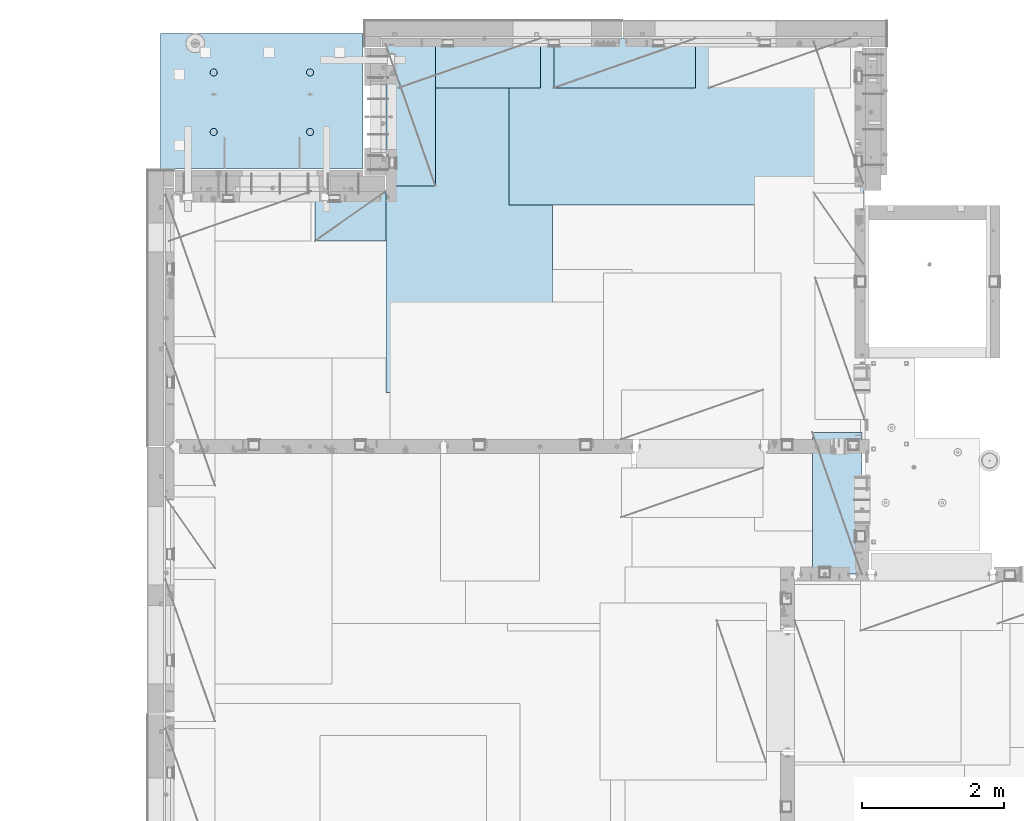
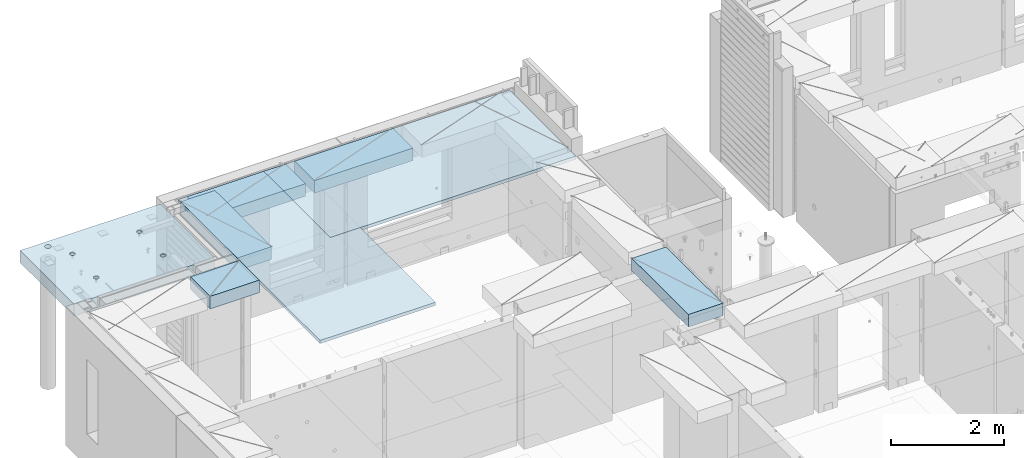
# One storey, part 176 of 309: 7 plates, 1 slab, 8 elements without a shape of their own.
"""IFC2X3 building model written with IfcOpenShell, lengths in millimetres."""

from ifc_helpers import new_model, si_unit, frame, origin_with_axes, place, context, subcontext, project, spatial, faceted_brep, material, type_object, element, aggregate, save


model = new_model("IFC2X3")

# Units and contexts
model_context = context("Model", 3, precision=1e-05, world=origin_with_axes())
body_context = subcontext(model_context, "Body", "Model", "MODEL_VIEW")
ifc_project = project(units=[si_unit("LENGTHUNIT", "METRE", prefix="MILLI"), si_unit("AREAUNIT", "SQUARE_METRE"), si_unit("VOLUMEUNIT", "CUBIC_METRE"), si_unit("MASSUNIT", "GRAM", prefix="KILO"), si_unit("TIMEUNIT", "SECOND"), si_unit("PLANEANGLEUNIT", "RADIAN"), si_unit("SOLIDANGLEUNIT", "STERADIAN"), si_unit("THERMODYNAMICTEMPERATUREUNIT", "DEGREE_CELSIUS"), si_unit("LUMINOUSINTENSITYUNIT", "LUMEN")], contexts=[model_context])

# Site, building, storey
site_placement = place(None, origin_with_axes())
site = spatial("IfcSite", under=ifc_project, at=site_placement, CompositionType="ELEMENT")
building_placement = place(site_placement, origin_with_axes())
building = spatial("IfcBuilding", under=site, at=building_placement, CompositionType="ELEMENT")
storey_placement = place(building_placement, origin_with_axes())
storey = spatial("IfcBuildingStorey", under=building, at=storey_placement, Name="7", CompositionType="ELEMENT", Elevation=0.0)

# Assembly, plate
assembly_1_placement = place(storey_placement, origin_with_axes())
assembly_1 = element("IfcElementAssembly", 1, at=assembly_1_placement, inside=storey, Name="Steel Assembly", AssemblyPlace="NOTDEFINED", PredefinedType="NOTDEFINED")
ifc_material_1 = material()
plate_type_1 = type_object("IfcPlateType", PredefinedType="NOTDEFINED")
plate_1_placement = place(assembly_1_placement, frame((12729.9998779297, 22740.0009765625, 102695.1), z_axis=(1.0, 0.0, 0.0), x_axis=(0.0, -1.0, 0.0)))
plate_1 = element("IfcPlate", 2, at=plate_1_placement, type_object=plate_type_1, material=ifc_material_1, context=body_context, shape_type="Brep", body=[
    faceted_brep([(0.0, -35.0, 0.0), (0.0, -35.0, 5000.0), (0.0, 35.0, 5000.0), (0.0, 35.0, 0.0), (2349.99951171875, -35.0, 5000.0), (2349.99951171875, 35.0, 5000.0), (2350.0, -35.0, 0.0), (2350.0, 35.0, 0.0)], [[[0, 1, 2, 3]], [[1, 4, 5, 2]], [[4, 6, 7, 5]], [[6, 0, 3, 7]], [[5, 7, 3, 2]], [[6, 4, 1, 0]]]),
])
aggregate(assembly_1, [plate_1])

assembly_2_placement = place(storey_placement, origin_with_axes())
assembly_2 = element("IfcElementAssembly", 3, at=assembly_2_placement, inside=storey, Name="Steel Assembly", AssemblyPlace="NOTDEFINED", PredefinedType="NOTDEFINED")
plate_2_placement = place(assembly_2_placement, frame((13340.0, 22740.0, 102695.1), z_axis=(0.0, -1.0, 0.0), x_axis=(-1.0, 3.00000001838171e-08, 0.0)))
plate_2 = element("IfcPlate", 4, at=plate_2_placement, type_object=plate_type_1, material=ifc_material_1, context=body_context, shape_type="Brep", body=[
    faceted_brep([(0.0, -35.0, 0.0), (0.0, -35.0, 5000.0), (0.0, 35.0, 5000.0), (0.0, 35.0, 0.0), (2349.99951171875, -35.0, 5000.0), (2349.99951171875, 35.0, 5000.0), (2350.0, -35.0, 0.0), (2350.0, 35.0, 0.0)], [[[0, 1, 2, 3]], [[1, 4, 5, 2]], [[4, 6, 7, 5]], [[6, 0, 3, 7]], [[5, 7, 3, 2]], [[6, 4, 1, 0]]]),
])
aggregate(assembly_2, [plate_2])

assembly_3_placement = place(storey_placement, origin_with_axes())
assembly_3 = element("IfcElementAssembly", 5, at=assembly_3_placement, inside=storey, Name="Steel Assembly", AssemblyPlace="NOTDEFINED", PredefinedType="NOTDEFINED")
plate_type_2 = type_object("IfcPlateType", PredefinedType="NOTDEFINED")
plate_3_placement = place(assembly_3_placement, frame((17710.0001220703, 15180.0, 102595.3), z_axis=(-1.0, 3.00000001838171e-08, 0.0), x_axis=(0.0, 1.0, 0.0)))
plate_3 = element("IfcPlate", 6, at=plate_3_placement, type_object=plate_type_2, material=ifc_material_1, Name="RE1", context=body_context, shape_type="Brep", body=[
    faceted_brep([(1.81898940354586e-12, -135.0, 1.81898940354586e-12), (0.0, -135.0, 699.999999999996), (0.0, 135.0, 699.999999999996), (1.81898940354586e-12, 135.0, 1.81898940354586e-12), (1999.99951171875, -135.0, 699.999999999993), (1999.99951171875, 135.0, 699.999999999993), (2000.0, -135.0, -3.63797880709171e-12), (2000.0, 135.0, -3.63797880709171e-12)], [[[0, 1, 2, 3]], [[1, 4, 5, 2]], [[4, 6, 7, 5]], [[6, 0, 3, 7]], [[5, 7, 3, 2]], [[6, 4, 1, 0]]]),
])
aggregate(assembly_3, [plate_3])

assembly_4_placement = place(storey_placement, origin_with_axes())
assembly_4 = element("IfcElementAssembly", 7, at=assembly_4_placement, inside=storey, Name="Steel Assembly", AssemblyPlace="NOTDEFINED", PredefinedType="NOTDEFINED")
plate_4_placement = place(assembly_4_placement, frame((13175.0, 22740.0001220703, 102595.3), z_axis=(0.0, -1.0, 0.0), x_axis=(-1.0, 3.00000001838171e-08, 0.0)))
plate_4 = element("IfcPlate", 8, at=plate_4_placement, type_object=plate_type_2, material=ifc_material_1, Name="RE1", context=body_context, shape_type="Brep", body=[
    faceted_brep([(1.81898940354586e-12, -135.0, 1.81898940354586e-12), (0.0, -135.0, 699.999999999996), (0.0, 135.0, 699.999999999996), (1.81898940354586e-12, 135.0, 1.81898940354586e-12), (1999.99951171875, -135.0, 699.999999999993), (1999.99951171875, 135.0, 699.999999999993), (2000.0, -135.0, -3.63797880709171e-12), (2000.0, 135.0, -3.63797880709171e-12)], [[[0, 1, 2, 3]], [[1, 4, 5, 2]], [[4, 6, 7, 5]], [[6, 0, 3, 7]], [[5, 7, 3, 2]], [[6, 4, 1, 0]]]),
])
aggregate(assembly_4, [plate_4])

assembly_5_placement = place(storey_placement, origin_with_axes())
assembly_5 = element("IfcElementAssembly", 9, at=assembly_5_placement, inside=storey, Name="Steel Assembly", AssemblyPlace="NOTDEFINED", PredefinedType="NOTDEFINED")
plate_5_placement = place(assembly_5_placement, frame((15360.0, 22740.0001220703, 102595.3), z_axis=(0.0, -1.0, 0.0), x_axis=(-1.0, 3.00000001838171e-08, 0.0)))
plate_5 = element("IfcPlate", 10, at=plate_5_placement, type_object=plate_type_2, material=ifc_material_1, Name="RE1", context=body_context, shape_type="Brep", body=[
    faceted_brep([(1.81898940354586e-12, -135.0, 1.81898940354586e-12), (0.0, -135.0, 699.999999999996), (0.0, 135.0, 699.999999999996), (1.81898940354586e-12, 135.0, 1.81898940354586e-12), (1999.99951171875, -135.0, 699.999999999993), (1999.99951171875, 135.0, 699.999999999993), (2000.0, -135.0, -3.63797880709171e-12), (2000.0, 135.0, -3.63797880709171e-12)], [[[0, 1, 2, 3]], [[1, 4, 5, 2]], [[4, 6, 7, 5]], [[6, 0, 3, 7]], [[5, 7, 3, 2]], [[6, 4, 1, 0]]]),
])
aggregate(assembly_5, [plate_5])

assembly_6_placement = place(storey_placement, origin_with_axes())
assembly_6 = element("IfcElementAssembly", 11, at=assembly_6_placement, inside=storey, Name="Steel Assembly", AssemblyPlace="NOTDEFINED", PredefinedType="NOTDEFINED")
plate_6_placement = place(assembly_6_placement, frame((10989.9998779297, 22660.0, 102595.3), z_axis=(1.0, 0.0, 0.0), x_axis=(0.0, -1.0, 0.0)))
plate_6 = element("IfcPlate", 12, at=plate_6_placement, type_object=plate_type_2, material=ifc_material_1, Name="RE1", context=body_context, shape_type="Brep", body=[
    faceted_brep([(1.81898940354586e-12, -135.0, 1.81898940354586e-12), (0.0, -135.0, 699.999999999996), (0.0, 135.0, 699.999999999996), (1.81898940354586e-12, 135.0, 1.81898940354586e-12), (1999.99951171875, -135.0, 699.999999999993), (1999.99951171875, 135.0, 699.999999999993), (2000.0, -135.0, -3.63797880709171e-12), (2000.0, 135.0, -3.63797880709171e-12)], [[[0, 1, 2, 3]], [[1, 4, 5, 2]], [[4, 6, 7, 5]], [[6, 0, 3, 7]], [[5, 7, 3, 2]], [[6, 4, 1, 0]]]),
])
aggregate(assembly_6, [plate_6])

assembly_7_placement = place(storey_placement, origin_with_axes())
assembly_7 = element("IfcElementAssembly", 13, at=assembly_7_placement, inside=storey, Name="Steel Assembly", AssemblyPlace="NOTDEFINED", PredefinedType="NOTDEFINED")
plate_7_placement = place(assembly_7_placement, frame((10990.0, 20580.0000000707, 102595.3), z_axis=(0.0, -1.0, 0.0), x_axis=(-1.0, 3.00000001838171e-08, 0.0)))
plate_7 = element("IfcPlate", 14, at=plate_7_placement, type_object=plate_type_2, material=ifc_material_1, Name="RE1_1/2", context=body_context, shape_type="Brep", body=[
    faceted_brep([(1.81898940354586e-12, -135.0, 1.81898940354586e-12), (0.0, -135.0, 699.999999999996), (0.0, 135.0, 699.999999999996), (1.81898940354586e-12, 135.0, 1.81898940354586e-12), (999.99951171875, -135.0, 700.0), (999.99951171875, 135.0, 700.0), (1000.0, -135.0, 0.0), (1000.0, 135.0, 0.0)], [[[0, 1, 2, 3]], [[1, 4, 5, 2]], [[4, 6, 7, 5]], [[6, 0, 3, 7]], [[5, 7, 3, 2]], [[6, 4, 1, 0]]]),
])
aggregate(assembly_7, [plate_7])

# Assembly, slab
assembly_8_placement = place(storey_placement, origin_with_axes())
assembly_8 = element("IfcElementAssembly", 15, at=assembly_8_placement, inside=storey, AssemblyPlace="NOTDEFINED", PredefinedType="REINFORCEMENT_UNIT")
ifc_material_2 = material(Name="CONCRETE/C35/45")
slab_type = type_object("IfcSlabType", PredefinedType="NOTDEFINED")
slab_placement = place(assembly_8_placement, frame((7810.00985681325, 20899.9965573523, 102575.0), z_axis=(-2.2639999995273e-06, 0.999999999997437, 0.0), x_axis=(0.999999999997251, 2.34499999952812e-06, 0.0)))
slab = element("IfcSlab", 16, at=slab_placement, type_object=slab_type, material=ifc_material_2, PredefinedType="FLOOR", context=body_context, shape_type="Brep", body=[
    faceted_brep([(2125.44400874935, -110.0, 1312.44480491596), (2139.38243873964, -110.0, 1319.54674746219), (2150.44405246897, -110.0, 1330.60830794105), (2157.54606211472, -110.0, 1344.54670374242), (2159.99327349015, -110.0, 1359.99754757078), (2157.54613649511, -110.0, 1375.44840317983), (2150.44419394888, -110.0, 1389.38683317012), (2139.38263347003, -110.0, 1400.44844689945), (2125.44423766865, -110.0, 1407.5504565452), (2109.9933938403, -110.0, 1409.99766792063), (2094.54253823125, -110.0, 1407.55053092559), (2080.60410824096, -110.0, 1400.44858837936), (2069.54249451162, -110.0, 1389.38702790051), (2062.44048486587, -110.0, 1375.44863209913), (2059.99327349044, -110.0, 1359.99778827078), (2062.44041048548, -110.0, 1344.54693266172), (2069.54235303171, -110.0, 1330.60850267144), (2080.60391351056, -110.0, 1319.5468889421), (2094.54230931194, -110.0, 1312.44487929635), (2109.9931531403, -110.0, 1309.99766792092), (2151.40731110266, -130.000000000015, 1390.08657519986), (2158.67834751904, -130.000000000015, 1375.81627782885), (2140.08238013622, -130.000000000015, 1401.41156068466), (2125.81211776814, -130.000000000015, 1408.68266579816), (2109.99339670578, -130.000000000015, 1411.1881441111), (2094.17466358222, -130.000000000015, 1408.68274194951), (2079.90436621121, -130.000000000015, 1401.41170553314), (2068.57938072642, -130.000000000015, 1390.08677456669), (2061.30827561291, -130.000000000015, 1375.81651219862), (2058.80279729997, -130.000000000015, 1359.99779113625), (2061.30819946156, -130.000000000015, 1344.1790580127), (2068.57923587794, -130.000000000015, 1329.90876064169), (2079.90416684438, -130.000000000015, 1318.58377515689), (2094.17442921246, -130.000000000015, 1311.31267004339), (2109.99315027482, -130.000000000015, 1308.80719173045), (2125.81188339837, -130.000000000015, 1311.31259389204), (2140.08218076939, -130.000000000015, 1318.58363030841), (2151.40716625418, -130.000000000015, 1329.90856127486), (2158.67827136769, -130.000000000015, 1344.17882364294), (2161.18374968063, -130.000000000015, 1359.9975447053), (765.444008782275, -110.0, 1312.44807834489), (779.382438772569, -110.0, 1319.55002089111), (790.444052501902, -110.0, 1330.61158136997), (797.546062147649, -110.0, 1344.54997717134), (799.99327352308, -110.0, 1360.0008209997), (797.546136528039, -110.0, 1375.45167660875), (790.444193981812, -110.0, 1389.39010659904), (779.382633502959, -110.0, 1400.45172032838), (765.444237701578, -110.0, 1407.55372997412), (749.993393873225, -110.0, 1410.00094134955), (734.542538264175, -110.0, 1407.55380435451), (720.604108273881, -110.0, 1400.45186180829), (709.54249454455, -110.0, 1389.39030132943), (702.440484898802, -110.0, 1375.45190552806), (699.993273523371, -110.0, 1360.0010616997), (702.440410518411, -110.0, 1344.55020609065), (709.54235306464, -110.0, 1330.61177610036), (720.603913543491, -110.0, 1319.55016237102), (734.542309344872, -110.0, 1312.44815272528), (749.993153173225, -110.0, 1310.00094134984), (798.678347551964, -130.0, 1375.81955125778), (801.183749713553, -130.0, 1360.00081813422), (791.407311135587, -130.0, 1390.08984862879), (780.082380169144, -130.0, 1401.41483411358), (765.812117801064, -130.0, 1408.68593922709), (749.993396738702, -130.0, 1411.19141754003), (734.174663615149, -130.0, 1408.68601537844), (719.904366244136, -130.0, 1401.41497896206), (708.579380759344, -130.0, 1390.09004799561), (701.308275645839, -130.0, 1375.81978562754), (698.802797332895, -130.0, 1360.00106456517), (701.308199494486, -130.0, 1344.18233144163), (708.579235910864, -130.0, 1329.91203407061), (719.904166877308, -130.0, 1318.58704858582), (734.174429245386, -130.0, 1311.31594347231), (749.99315030775, -130.0, 1308.81046515937), (765.811883431301, -130.0, 1311.31586732096), (780.082180802316, -130.0, 1318.58690373734), (791.407166287107, -130.0, 1329.91183470378), (798.678271400611, -130.0, 1344.18209707186), (2859.98999023438, -130.0, -1.11685949377716e-09), (0.0, -130.0, -3.63797880709171e-12), (0.0, 130.0, -1.81898940354586e-12), (2859.98999023438, 130.0, -1.11685949377716e-09), (2859.99145507813, -130.0, 1910.00366210938), (2859.99145507813, 130.0, 1910.00366210938), (0.00121913256589323, -130.0, 1910.00366210938), (0.00121913256589323, 130.0, 1910.00366210938), (538.534303374119, 130.0, 1805.28415037586), (525.260430799499, 130.0, 1818.55808685106), (508.534355837841, 130.0, 1827.08049842596), (489.993343243817, 130.0, 1830.01715207647), (471.452316512958, 130.0, 1827.08058768242), (454.726200524605, 130.0, 1818.55825662695), (441.452264049407, 130.0, 1805.28438405233), (432.929852474508, 130.0, 1788.55830909067), (429.993198823991, 130.0, 1770.01729649665), (432.929763218039, 130.0, 1751.47626976578), (441.452094273514, 130.0, 1734.75015377744), (454.725966848137, 130.0, 1721.47621730223), (471.452041809793, 130.0, 1712.95380572733), (489.993054403818, 130.0, 1710.01715207682), (508.534081134676, 130.0, 1712.95371647087), (525.260197123031, 130.0, 1721.47604752634), (538.534133598227, 130.0, 1734.74992010097), (547.056545173127, 130.0, 1751.47599506262), (549.993198823642, 130.0, 1770.01700765665), (547.056634429597, 130.0, 1788.55803438751), (547.056634429597, -130.0, 1788.55803438751), (549.993198823642, -130.0, 1770.01700765665), (538.534303374119, -130.0, 1805.28415037586), (525.260430799499, -130.0, 1818.55808685106), (508.534355837841, -130.0, 1827.08049842596), (489.993343243817, -130.0, 1830.01715207647), (471.452316512958, -130.0, 1827.08058768242), (454.726200524605, -130.0, 1818.55825662695), (441.452264049407, -130.0, 1805.28438405233), (432.929852474508, -130.0, 1788.55830909067), (429.993198823991, -130.0, 1770.01729649665), (432.929763218039, -130.0, 1751.47626976578), (441.452094273514, -130.0, 1734.75015377744), (454.725966848137, -130.0, 1721.47621730223), (471.452041809793, -130.0, 1712.95380572733), (489.993054403818, -130.0, 1710.01715207682), (508.534081134676, -130.0, 1712.95371647087), (525.260197123031, -130.0, 1721.47604752634), (538.534133598227, -130.0, 1734.74992010097), (547.056545173127, -130.0, 1751.47599506262), (765.441986918462, -110.0, 472.446247293799), (779.380416908756, -110.0, 479.548189840025), (790.442030638089, -110.0, 490.609750318879), (797.544040283836, -110.0, 504.548146120258), (799.991251659267, -110.0, 519.998989948614), (797.544114664226, -110.0, 535.449845557669), (790.442172117999, -110.0, 549.388275547957), (779.380611639148, -110.0, 560.44988927729), (765.442215837766, -110.0, 567.551898923037), (749.991372009414, -110.0, 569.999110298468), (734.540516400362, -110.0, 567.551973303427), (720.60208641007, -110.0, 560.450030757202), (709.540472680737, -110.0, 549.388470278347), (702.438463034989, -110.0, 535.450074476972), (699.991251659558, -110.0, 519.999230648613), (702.438388654598, -110.0, 504.548375039562), (709.540331200828, -110.0, 490.609945049269), (720.601891679678, -110.0, 479.548331319937), (734.540287481059, -110.0, 472.44632167419), (749.991131309413, -110.0, 469.999110298759), (798.676325688151, -130.0, 535.817720206687), (801.18172784974, -130.0, 519.998987083138), (791.405289271774, -130.0, 550.088017577702), (780.080358305331, -130.0, 561.413003062498), (765.810095937251, -130.0, 568.684108175999), (749.99137487489, -130.0, 571.189586488941), (734.172641751336, -130.0, 568.684184327351), (719.902344380323, -130.0, 561.413147910978), (708.577358895531, -130.0, 550.088216944529), (701.306253782026, -130.0, 535.817954576451), (698.800775469083, -130.0, 519.999233514089), (701.306177630673, -130.0, 504.180500390539), (708.577214047051, -130.0, 489.910203019524), (719.902145013495, -130.0, 478.585217534732), (734.172407381573, -130.0, 471.314112421227), (749.991128443937, -130.0, 468.808634108285), (765.809861567488, -130.0, 471.314036269876), (780.080158938503, -130.0, 478.585072686252), (791.405144423294, -130.0, 489.910003652698), (798.676249536798, -130.0, 504.180266020776), (2125.44198694826, -110.0, 472.442973901358), (2139.38041693855, -110.0, 479.544916447583), (2150.44203066788, -110.0, 490.606476926438), (2157.54404031363, -110.0, 504.544872727816), (2159.99125168906, -110.0, 519.995716556172), (2157.54411469402, -110.0, 535.446572165227), (2150.44217214779, -110.0, 549.385002155515), (2139.38061166894, -110.0, 560.446615884848), (2125.44221586756, -110.0, 567.548625530595), (2109.99137203921, -110.0, 569.995836906026), (2094.54051643016, -110.0, 567.548699910985), (2080.60208643987, -110.0, 560.44675736476), (2069.54047271053, -110.0, 549.385196885905), (2062.43846306479, -110.0, 535.44680108453), (2059.99125168935, -110.0, 519.995957256171), (2062.43838868439, -110.0, 504.54510164712), (2069.54033123062, -110.0, 490.606671656828), (2080.60189170947, -110.0, 479.545057927495), (2094.54028751086, -110.0, 472.443048281748), (2109.99113133921, -110.0, 469.995836906317), (2158.67632571795, -130.000000000015, 535.814446814245), (2161.18172787954, -130.000000000015, 519.995713690696), (2151.40528930157, -130.000000000015, 550.08474418526), (2140.08035833513, -130.000000000015, 561.409729670057), (2125.81009596705, -130.000000000015, 568.680834783558), (2109.99137490468, -130.000000000015, 571.186313096499), (2094.17264178113, -130.000000000015, 568.680910934909), (2079.90234441012, -130.000000000015, 561.409874518537), (2068.57735892533, -130.000000000015, 550.084943552087), (2061.30625381182, -130.000000000015, 535.814681184009), (2058.80077549888, -130.000000000015, 519.995960121647), (2061.30617766047, -130.000000000015, 504.177226998097), (2068.57721407685, -130.000000000015, 489.906929627083), (2079.90214504329, -130.000000000015, 478.58194414229), (2094.17240741137, -130.000000000015, 471.310839028785), (2109.99112847373, -130.000000000015, 468.805360715844), (2125.80986159728, -130.000000000015, 471.310762877434), (2140.0801589683, -130.000000000015, 478.58179929381), (2151.40514445309, -130.000000000015, 489.906730260256), (2158.6762495666, -130.000000000015, 504.176992628334)], [[[0, 1, 2, 3, 4, 5, 6, 7, 8, 9, 10, 11, 12, 13, 14, 15, 16, 17, 18, 19]], [[20, 6, 5, 21]], [[22, 7, 6, 20]], [[23, 8, 7, 22]], [[24, 9, 8, 23]], [[25, 10, 9, 24]], [[26, 11, 10, 25]], [[27, 12, 11, 26]], [[28, 13, 12, 27]], [[29, 14, 13, 28]], [[30, 15, 14, 29]], [[31, 16, 15, 30]], [[32, 17, 16, 31]], [[33, 18, 17, 32]], [[34, 19, 18, 33]], [[35, 0, 19, 34]], [[36, 1, 0, 35]], [[37, 2, 1, 36]], [[38, 3, 2, 37]], [[39, 4, 3, 38]], [[21, 5, 4, 39]], [[40, 41, 42, 43, 44, 45, 46, 47, 48, 49, 50, 51, 52, 53, 54, 55, 56, 57, 58, 59]], [[60, 45, 44, 61]], [[62, 46, 45, 60]], [[63, 47, 46, 62]], [[64, 48, 47, 63]], [[65, 49, 48, 64]], [[66, 50, 49, 65]], [[67, 51, 50, 66]], [[68, 52, 51, 67]], [[69, 53, 52, 68]], [[70, 54, 53, 69]], [[71, 55, 54, 70]], [[72, 56, 55, 71]], [[73, 57, 56, 72]], [[74, 58, 57, 73]], [[75, 59, 58, 74]], [[76, 40, 59, 75]], [[77, 41, 40, 76]], [[78, 42, 41, 77]], [[79, 43, 42, 78]], [[61, 44, 43, 79]], [[80, 81, 82, 83]], [[84, 80, 83, 85]], [[86, 84, 85, 87]], [[81, 86, 87, 82]], [[85, 83, 82, 87], [88, 89, 90, 91, 92, 93, 94, 95, 96, 97, 98, 99, 100, 101, 102, 103, 104, 105, 106, 107]], [[108, 107, 106, 109]], [[110, 88, 107, 108]], [[111, 89, 88, 110]], [[112, 90, 89, 111]], [[113, 91, 90, 112]], [[114, 92, 91, 113]], [[115, 93, 92, 114]], [[116, 94, 93, 115]], [[117, 95, 94, 116]], [[118, 96, 95, 117]], [[119, 97, 96, 118]], [[120, 98, 97, 119]], [[121, 99, 98, 120]], [[122, 100, 99, 121]], [[123, 101, 100, 122]], [[124, 102, 101, 123]], [[125, 103, 102, 124]], [[126, 104, 103, 125]], [[127, 105, 104, 126]], [[109, 106, 105, 127]], [[128, 129, 130, 131, 132, 133, 134, 135, 136, 137, 138, 139, 140, 141, 142, 143, 144, 145, 146, 147]], [[148, 133, 132, 149]], [[150, 134, 133, 148]], [[151, 135, 134, 150]], [[152, 136, 135, 151]], [[153, 137, 136, 152]], [[154, 138, 137, 153]], [[155, 139, 138, 154]], [[156, 140, 139, 155]], [[157, 141, 140, 156]], [[158, 142, 141, 157]], [[159, 143, 142, 158]], [[160, 144, 143, 159]], [[161, 145, 144, 160]], [[162, 146, 145, 161]], [[163, 147, 146, 162]], [[164, 128, 147, 163]], [[165, 129, 128, 164]], [[166, 130, 129, 165]], [[167, 131, 130, 166]], [[149, 132, 131, 167]], [[168, 169, 170, 171, 172, 173, 174, 175, 176, 177, 178, 179, 180, 181, 182, 183, 184, 185, 186, 187]], [[188, 173, 172, 189]], [[190, 174, 173, 188]], [[191, 175, 174, 190]], [[192, 176, 175, 191]], [[193, 177, 176, 192]], [[194, 178, 177, 193]], [[195, 179, 178, 194]], [[196, 180, 179, 195]], [[197, 181, 180, 196]], [[198, 182, 181, 197]], [[199, 183, 182, 198]], [[200, 184, 183, 199]], [[201, 185, 184, 200]], [[202, 186, 185, 201]], [[203, 187, 186, 202]], [[204, 168, 187, 203]], [[205, 169, 168, 204]], [[206, 170, 169, 205]], [[207, 171, 170, 206]], [[189, 172, 171, 207]], [[80, 84, 86, 81], [37, 36, 35, 34, 33, 32, 31, 30, 29, 28, 27, 26, 25, 24, 23, 22, 20, 21, 39, 38], [206, 205, 204, 203, 202, 201, 200, 199, 198, 197, 196, 195, 194, 193, 192, 191, 190, 188, 189, 207], [166, 165, 164, 163, 162, 161, 160, 159, 158, 157, 156, 155, 154, 153, 152, 151, 150, 148, 149, 167], [126, 125, 124, 123, 122, 121, 120, 119, 118, 117, 116, 115, 114, 113, 112, 111, 110, 108, 109, 127], [78, 77, 76, 75, 74, 73, 72, 71, 70, 69, 68, 67, 66, 65, 64, 63, 62, 60, 61, 79]]]),
])
aggregate(assembly_8, [slab])

save(model, "model.ifc")
